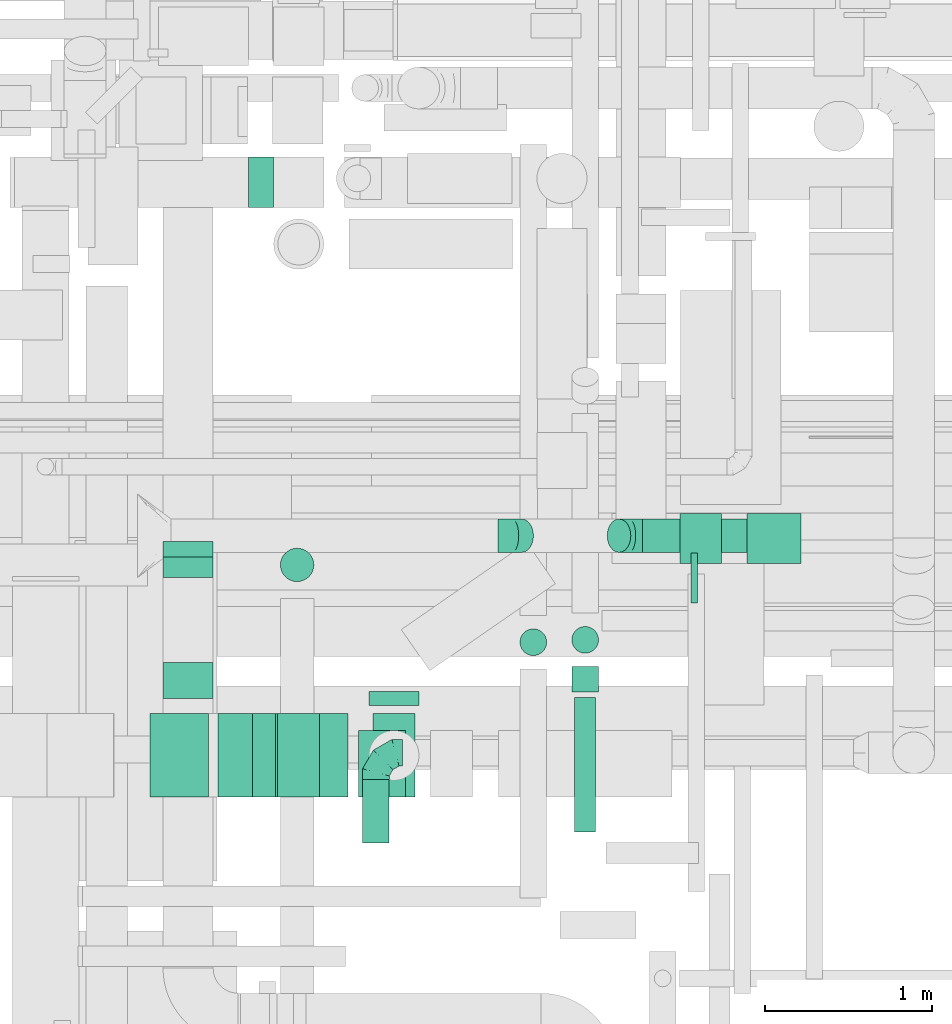
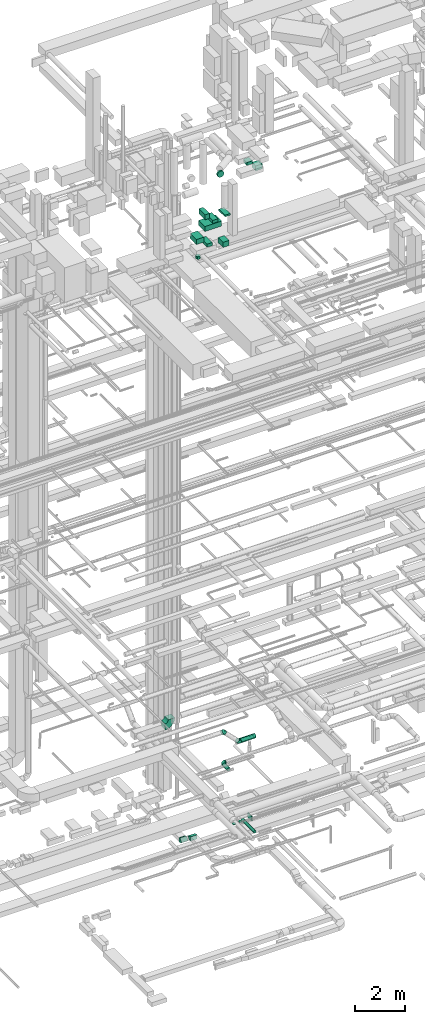
# One storey, part 140 of 337: 18 flow segments, 6 flow fittings.
"""IFC2X3 building model written with IfcOpenShell, lengths in millimetres."""

from ifc_helpers import new_model, entity, si_unit, converted_unit, derived_unit, direction, frame, frame_2d, origin, origin_2d_with_axis, place, context, subcontext, project, spatial, polyline, circle_curve, parameter, trimmed, segment, composite_curve, rectangle, circle, outline, extrude, faceted_brep, source, transform, mapped, material, type_object, type_shapes, element, save


model = new_model("IFC2X3")

# Units and contexts
model_context = context("Model", 3, precision=0.01, world=origin(), true_north=direction((6.12303176911189e-17, 1.0)))
body_context = subcontext(model_context, "Body", "Model", "MODEL_VIEW")
ifc_project = project(units=[si_unit("LENGTHUNIT", "METRE", prefix="MILLI"), si_unit("AREAUNIT", "SQUARE_METRE"), si_unit("VOLUMEUNIT", "CUBIC_METRE"), converted_unit("PLANEANGLEUNIT", "DEGREE", entity("IfcRatioMeasure", 0.0174532925199433), si_unit("PLANEANGLEUNIT", "RADIAN"), dimensions=[0, 0, 0, 0, 0, 0, 0]), si_unit("MASSUNIT", "GRAM", prefix="KILO"), derived_unit("MASSDENSITYUNIT", [(si_unit("MASSUNIT", "GRAM", prefix="KILO"), 1), (si_unit("LENGTHUNIT", "METRE"), -3)]), derived_unit("MOMENTOFINERTIAUNIT", [(si_unit("LENGTHUNIT", "METRE"), 4)]), si_unit("TIMEUNIT", "SECOND"), si_unit("FREQUENCYUNIT", "HERTZ"), si_unit("THERMODYNAMICTEMPERATUREUNIT", "DEGREE_CELSIUS"), derived_unit("THERMALTRANSMITTANCEUNIT", [(si_unit("MASSUNIT", "GRAM", prefix="KILO"), 1), (si_unit("THERMODYNAMICTEMPERATUREUNIT", "KELVIN"), -1), (si_unit("TIMEUNIT", "SECOND"), -3)]), derived_unit("VOLUMETRICFLOWRATEUNIT", [(si_unit("LENGTHUNIT", "METRE"), 3), (si_unit("TIMEUNIT", "SECOND"), -1)]), derived_unit("MASSFLOWRATEUNIT", [(si_unit("MASSUNIT", "GRAM", prefix="KILO"), 1), (si_unit("TIMEUNIT", "SECOND"), -1)]), derived_unit("ROTATIONALFREQUENCYUNIT", [(si_unit("TIMEUNIT", "SECOND"), -1)]), si_unit("ELECTRICCURRENTUNIT", "AMPERE"), si_unit("ELECTRICVOLTAGEUNIT", "VOLT"), si_unit("POWERUNIT", "WATT"), si_unit("FORCEUNIT", "NEWTON", prefix="KILO"), si_unit("ILLUMINANCEUNIT", "LUX"), si_unit("LUMINOUSFLUXUNIT", "LUMEN"), si_unit("LUMINOUSINTENSITYUNIT", "CANDELA"), derived_unit("USERDEFINED", [(si_unit("MASSUNIT", "GRAM", prefix="KILO"), -1), (si_unit("LENGTHUNIT", "METRE"), -2), (si_unit("TIMEUNIT", "SECOND"), 3), (si_unit("LUMINOUSFLUXUNIT", "LUMEN"), 1)]), derived_unit("LINEARVELOCITYUNIT", [(si_unit("LENGTHUNIT", "METRE"), 1), (si_unit("TIMEUNIT", "SECOND"), -1)]), si_unit("PRESSUREUNIT", "PASCAL"), derived_unit("USERDEFINED", [(si_unit("LENGTHUNIT", "METRE"), -2), (si_unit("MASSUNIT", "GRAM", prefix="KILO"), 1), (si_unit("TIMEUNIT", "SECOND"), -2)]), derived_unit("LINEARFORCEUNIT", [(si_unit("MASSUNIT", "GRAM", prefix="KILO"), 1), (si_unit("LENGTHUNIT", "METRE"), 1), (si_unit("TIMEUNIT", "SECOND"), -2), (si_unit("LENGTHUNIT", "METRE"), -1)]), derived_unit("PLANARFORCEUNIT", [(si_unit("MASSUNIT", "GRAM", prefix="KILO"), 1), (si_unit("LENGTHUNIT", "METRE"), 1), (si_unit("TIMEUNIT", "SECOND"), -2), (si_unit("LENGTHUNIT", "METRE"), -2)])], contexts=[model_context])

# Site, building, storey
site_placement = place(None, origin())
site = spatial("IfcSite", under=ifc_project, at=site_placement, CompositionType="ELEMENT")
building_placement = place(site_placement, origin())
building = spatial("IfcBuilding", under=site, at=building_placement, CompositionType="ELEMENT")
storey_placement = place(building_placement, origin())
storey = spatial("IfcBuildingStorey", under=building, at=storey_placement, CompositionType="ELEMENT", Elevation=0.0)

# Flow segments
duct_segment_type_1 = type_object("IfcDuctSegmentType", PredefinedType="NOTDEFINED")
flow_segment_1_placement = place(storey_placement, frame((33488.7, 9095.01, -1125.0)))
element("IfcFlowSegment", 1, at=flow_segment_1_placement, inside=storey, type_object=duct_segment_type_1, context=body_context, shape_type="SweptSolid", body=[
    extrude(rectangle(XDim=39.0201967499437, YDim=300.0, at=origin_2d_with_axis()), frame((19.51, 150.0, 0.0), z_axis=(0.0, 0.0, 1.0), x_axis=(-1.0, 0.0, 0.0)), (0.0, 0.0, 1.0), 250.0),
])
duct_segment_type_2 = type_object("IfcDuctSegmentType", PredefinedType="NOTDEFINED")
flow_segment_2_placement = place(storey_placement, frame((32462.52, 8780.33, -790.0)))
element("IfcFlowSegment", 2, at=flow_segment_2_placement, inside=storey, type_object=duct_segment_type_2, context=body_context, shape_type="SweptSolid", body=[
    extrude(circle(Radius=80.0, at=origin_2d_with_axis()), frame((81.6, 81.6, 0.0)), (0.0, 0.0, 1.0), 30.0000000000002),
])
flow_segment_3_placement = place(storey_placement, frame((33198.39, 9397.48, 2598.4)))
element("IfcFlowSegment", 3, at=flow_segment_3_placement, inside=storey, type_object=duct_segment_type_2, context=body_context, shape_type="SweptSolid", body=[
    extrude(circle(Radius=100.0, at=origin_2d_with_axis()), frame((0.0, 101.6, 101.6), z_axis=(1.0, 0.0, 0.0), x_axis=(0.0, -1.0, 0.0)), (0.0, 0.0, 1.0), 688.528137423898),
])
flow_segment_4_placement = place(storey_placement, frame((31520.43, 7660.92, 2868.4)))
element("IfcFlowSegment", 4, at=flow_segment_4_placement, inside=storey, type_object=duct_segment_type_2, context=body_context, shape_type="SweptSolid", body=[
    extrude(circle(Radius=80.0, at=origin_2d_with_axis()), frame((81.6, 0.0, 81.6), z_axis=(0.0, 1.0, 0.0), x_axis=(-1.0, 0.0, 0.0)), (0.0, 0.0, 1.0), 379.100000000156),
])
flow_segment_5_placement = place(storey_placement, frame((31558.4, 8484.5, 31548.4)))
element("IfcFlowSegment", 5, at=flow_segment_5_placement, inside=storey, type_object=duct_segment_type_2, context=body_context, shape_type="SweptSolid", body=[
    extrude(circle(Radius=150.0, at=origin_2d_with_axis()), frame((151.6, 0.0, 151.6), z_axis=(0.0, 1.0, 0.0), x_axis=(1.0, 0.0, 0.0)), (0.0, 0.0, 1.0), 82.9124965860281),
])
flow_segment_6_placement = place(storey_placement, frame((31028.91, 9222.81, 27270.0)))
element("IfcFlowSegment", 6, at=flow_segment_6_placement, inside=storey, type_object=duct_segment_type_2, context=body_context, shape_type="SweptSolid", body=[
    extrude(circle(Radius=100.0, at=origin_2d_with_axis()), frame((101.6, 101.6, 0.0), z_axis=(0.0, 0.0, 1.0), x_axis=(-1.0, 0.0, 0.0)), (0.0, 0.0, 1.0), 129.999999999992),
])
flow_segment_7_placement = place(storey_placement, frame((32790.38, 7724.77, -664.1)))
element("IfcFlowSegment", 7, at=flow_segment_7_placement, inside=storey, type_object=duct_segment_type_2, context=body_context, shape_type="SweptSolid", body=[
    extrude(circle(Radius=62.5, at=origin_2d_with_axis()), frame((64.1, 0.0, 64.1), z_axis=(0.0, 1.0, 0.0), x_axis=(1.0, 0.0, 0.0)), (0.0, 0.0, 1.0), 805.000000000003),
])
flow_segment_8_placement = place(storey_placement, frame((32772.88, 8564.77, -681.6)))
element("IfcFlowSegment", 8, at=flow_segment_8_placement, inside=storey, type_object=duct_segment_type_2, context=body_context, shape_type="SweptSolid", body=[
    extrude(circle(Radius=80.0, at=origin_2d_with_axis()), frame((81.6, 0.0, 81.6), z_axis=(0.0, 1.0, 0.0), x_axis=(-1.0, 0.0, 0.0)), (0.0, 0.0, 1.0), 151.070569999958),
])
flow_segment_9_placement = place(storey_placement, frame((32772.88, 8794.25, -790.0)))
element("IfcFlowSegment", 9, at=flow_segment_9_placement, inside=storey, type_object=duct_segment_type_2, context=body_context, shape_type="SweptSolid", body=[
    extrude(circle(Radius=80.0, at=origin_2d_with_axis()), frame((81.6, 81.6, 0.0), z_axis=(0.0, 0.0, 1.0), x_axis=(-1.0, 0.0, 0.0)), (0.0, 0.0, 1.0), 30.0000000000277),
])
duct_segment_type_3 = type_object("IfcDuctSegmentType", PredefinedType="NOTDEFINED")
flow_segment_10_placement = place(storey_placement, frame((30655.36, 7934.5, 29575.0)))
element("IfcFlowSegment", 10, at=flow_segment_10_placement, inside=storey, type_object=duct_segment_type_3, context=body_context, shape_type="SweptSolid", body=[
    extrude(rectangle(XDim=779.641735586025, YDim=500.0, at=origin_2d_with_axis()), frame((389.82, 250.0, 0.0)), (0.0, 0.0, 1.0), 250.000000000004),
])
flow_segment_11_placement = place(storey_placement, frame((30658.06, 7934.5, 30150.0)))
element("IfcFlowSegment", 11, at=flow_segment_11_placement, inside=storey, type_object=duct_segment_type_3, context=body_context, shape_type="SweptSolid", body=[
    extrude(rectangle(XDim=205.855431162575, YDim=500.0, at=origin_2d_with_axis()), frame((102.93, 250.0, 0.0)), (0.0, 0.0, 1.0), 250.000000000004),
])
flow_segment_12_placement = place(storey_placement, frame((31013.92, 7934.5, 29845.0)))
element("IfcFlowSegment", 12, at=flow_segment_12_placement, inside=storey, type_object=duct_segment_type_3, context=body_context, shape_type="SweptSolid", body=[
    extrude(rectangle(XDim=250.000000000004, YDim=500.0, at=origin_2d_with_axis()), frame((125.0, 250.0, 0.0), z_axis=(0.0, 0.0, 1.0), x_axis=(-1.0, 0.0, 0.0)), (0.0, 0.0, 1.0), 154.999999999978),
])
flow_segment_13_placement = place(storey_placement, frame((31585.0, 7934.5, 29975.0)))
element("IfcFlowSegment", 13, at=flow_segment_13_placement, inside=storey, type_object=duct_segment_type_3, context=body_context, shape_type="SweptSolid", body=[
    extrude(rectangle(XDim=250.000000000004, YDim=500.0, at=origin_2d_with_axis()), frame((125.0, 250.0, 0.0)), (0.0, 0.0, 1.0), 76.9999999999868),
])
flow_segment_14_placement = place(storey_placement, frame((31497.03, 7934.51, 28500.0)))
element("IfcFlowSegment", 14, at=flow_segment_14_placement, inside=storey, type_object=duct_segment_type_3, context=body_context, shape_type="SweptSolid", body=[
    extrude(rectangle(XDim=282.46671500016, YDim=400.0, at=origin_2d_with_axis()), frame((141.23, 200.0, 0.0), z_axis=(0.0, 0.0, 1.0), x_axis=(-1.0, 0.0, 0.0)), (0.0, 0.0, 1.0), 250.000000000004),
])
flow_segment_15_placement = place(storey_placement, frame((30250.84, 7934.5, 29075.0)))
element("IfcFlowSegment", 15, at=flow_segment_15_placement, inside=storey, type_object=duct_segment_type_3, context=body_context, shape_type="SweptSolid", body=[
    extrude(rectangle(XDim=350.488799910469, YDim=500.0, at=origin_2d_with_axis()), frame((175.24, 250.0, 0.0), z_axis=(0.0, 0.0, 1.0), x_axis=(-1.0, 0.0, 0.0)), (0.0, 0.0, 1.0), 250.000000000004),
])
flow_segment_16_placement = place(storey_placement, frame((30751.33, 7934.5, 28770.0)))
element("IfcFlowSegment", 16, at=flow_segment_16_placement, inside=storey, type_object=duct_segment_type_3, context=body_context, shape_type="SweptSolid", body=[
    extrude(rectangle(XDim=250.000000000004, YDim=500.0, at=origin_2d_with_axis()), frame((125.0, 250.0, 0.0), z_axis=(0.0, 0.0, 1.0), x_axis=(-1.0, 0.0, 0.0)), (0.0, 0.0, 1.0), 154.999999999956),
])
flow_segment_17_placement = place(storey_placement, frame((33821.59, 9332.41, 30600.0)))
element("IfcFlowSegment", 17, at=flow_segment_17_placement, inside=storey, type_object=duct_segment_type_3, context=body_context, shape_type="SweptSolid", body=[
    extrude(rectangle(XDim=324.394797118785, YDim=300.0, at=origin_2d_with_axis()), frame((162.2, 150.0, 0.0), z_axis=(0.0, 0.0, 1.0), x_axis=(-1.0, 0.0, 0.0)), (0.0, 0.0, 1.0), 250.000000000004),
])
flow_segment_18_placement = place(storey_placement, frame((33421.59, 9332.41, 31000.0)))
element("IfcFlowSegment", 18, at=flow_segment_18_placement, inside=storey, type_object=duct_segment_type_3, context=body_context, shape_type="SweptSolid", body=[
    extrude(rectangle(XDim=300.000000000001, YDim=249.999999999999, at=origin_2d_with_axis()), frame((125.0, 150.0, 0.0), z_axis=(0.0, 0.0, 1.0), x_axis=(0.0, -1.0, 0.0)), (0.0, 0.0, 1.0), 154.999999999999),
])

# Flow fittings
ifc_material = material()
duct_fitting_type_1 = type_object("IfcDuctFittingType", PredefinedType="NOTDEFINED", material=ifc_material)
shared_shape_1 = source(origin(), body_context, "Body", "Brep", [
    faceted_brep([(-160.0, 0.0, -80.0), (-160.0, -20.71, -77.27), (-160.0, -40.0, -69.28), (-160.0, -56.57, -56.57), (-160.0, -69.28, -40.0), (-160.0, -77.27, -20.71), (-160.0, -80.0, 0.0), (-160.0, -77.27, 20.71), (-160.0, -69.28, 40.0), (-160.0, -56.57, 56.57), (-160.0, -40.0, 69.28), (-160.0, -20.71, 77.27), (-160.0, 0.0, 80.0), (-160.0, 20.71, 77.27), (-160.0, 40.0, 69.28), (-160.0, 56.57, 56.57), (-160.0, 69.28, 40.0), (-160.0, 77.27, 20.71), (-160.0, 80.0, 0.0), (-160.0, 77.27, -20.71), (-160.0, 69.28, -40.0), (-160.0, 56.57, -56.57), (-160.0, 40.0, -69.28), (-160.0, 20.71, -77.27), (-122.68, 20.71, 77.27), (-127.85, 40.0, 69.28), (-117.13, 0.0, 80.0), (-132.29, 56.57, 56.57), (-137.83, 77.27, 20.71), (-138.56, 80.0, 0.0), (-135.69, 69.28, 40.0), (-135.69, 69.28, -40.0), (-132.29, 56.57, -56.57), (-137.83, 77.27, -20.71), (-122.68, 20.71, -77.27), (-117.13, 0.0, -80.0), (-127.85, 40.0, -69.28), (-111.58, -20.71, -77.27), (-106.41, -40.0, -69.28), (-101.97, -56.57, -56.57), (-98.56, -69.28, -40.0), (-96.42, -77.27, -20.71), (-95.69, -80.0, 0.0), (-96.42, -77.27, 20.71), (-98.56, -69.28, 40.0), (-101.97, -56.57, 56.57), (-106.41, -40.0, 69.28), (-111.58, -20.71, 77.27), (-58.03, 58.03, 77.27), (-72.15, 72.15, 69.28), (-42.87, 42.87, 80.0), (-84.28, 84.28, 56.57), (-93.59, 93.59, 40.0), (-99.44, 99.44, 20.71), (-101.44, 101.44, 0.0), (-99.44, 99.44, -20.71), (-93.59, 93.59, -40.0), (-84.28, 84.28, -56.57), (-58.03, 58.03, -77.27), (-42.87, 42.87, -80.0), (-72.15, 72.15, -69.28), (-27.71, 27.71, -77.27), (-13.59, 13.59, -69.28), (-1.46, 1.46, -56.57), (7.85, -7.85, -40.0), (13.7, -13.7, -20.71), (15.69, -15.69, 0.0), (13.7, -13.7, 20.71), (7.85, -7.85, 40.0), (-1.46, 1.46, 56.57), (-13.59, 13.59, 69.28), (-27.71, 27.71, 77.27), (-20.71, 122.68, 77.27), (-40.0, 127.85, 69.28), (0.0, 117.13, 80.0), (-56.57, 132.29, 56.57), (-69.28, 135.69, 40.0), (-77.27, 137.83, 20.71), (-80.0, 138.56, 0.0), (-77.27, 137.83, -20.71), (-69.28, 135.69, -40.0), (-56.57, 132.29, -56.57), (-20.71, 122.68, -77.27), (0.0, 117.13, -80.0), (-40.0, 127.85, -69.28), (20.71, 111.58, -77.27), (40.0, 106.41, -69.28), (56.57, 101.97, -56.57), (69.28, 98.56, -40.0), (77.27, 96.42, -20.71), (80.0, 95.69, 0.0), (77.27, 96.42, 20.71), (69.28, 98.56, 40.0), (56.57, 101.97, 56.57), (40.0, 106.41, 69.28), (20.71, 111.58, 77.27), (-20.71, 160.0, -77.27), (-40.0, 160.0, -69.28), (-56.57, 160.0, -56.57), (-69.28, 160.0, -40.0), (-77.27, 160.0, -20.71), (-80.0, 160.0, 0.0), (-77.27, 160.0, 20.71), (-69.28, 160.0, 40.0), (-56.57, 160.0, 56.57), (-40.0, 160.0, 69.28), (-20.71, 160.0, 77.27), (0.0, 160.0, 80.0), (20.71, 160.0, 77.27), (40.0, 160.0, 69.28), (56.57, 160.0, 56.57), (69.28, 160.0, 40.0), (77.27, 160.0, 20.71), (80.0, 160.0, 0.0), (77.27, 160.0, -20.71), (69.28, 160.0, -40.0), (56.57, 160.0, -56.57), (40.0, 160.0, -69.28), (20.71, 160.0, -77.27), (0.0, 160.0, -80.0)], [[[0, 1, 2, 3, 4, 5, 6, 7, 8, 9, 10, 11, 12, 13, 14, 15, 16, 17, 18, 19, 20, 21, 22, 23]], [[24, 25, 14, 13]], [[26, 24, 13, 12]], [[14, 25, 27, 15]], [[28, 29, 18, 17]], [[30, 28, 17, 16]], [[15, 27, 30, 16]], [[20, 31, 32, 21]], [[33, 31, 20, 19]], [[18, 29, 33, 19]], [[34, 35, 0, 23]], [[36, 34, 23, 22]], [[32, 36, 22, 21]], [[1, 0, 35, 37]], [[2, 1, 37, 38]], [[3, 2, 38, 39]], [[5, 4, 40, 41]], [[6, 5, 41, 42]], [[39, 40, 4, 3]], [[6, 42, 43, 7]], [[7, 43, 44, 8]], [[8, 44, 45, 9]], [[9, 45, 46, 10]], [[10, 46, 47, 11]], [[26, 12, 11, 47]], [[48, 49, 25, 24]], [[50, 48, 24, 26]], [[27, 25, 49, 51]], [[52, 53, 28, 30]], [[51, 52, 30, 27]], [[29, 28, 53, 54]], [[55, 56, 31, 33]], [[54, 55, 33, 29]], [[32, 31, 56, 57]], [[58, 59, 35, 34]], [[60, 58, 34, 36]], [[57, 60, 36, 32]], [[37, 35, 59, 61]], [[38, 37, 61, 62]], [[39, 38, 62, 63]], [[41, 40, 64, 65]], [[42, 41, 65, 66]], [[63, 64, 40, 39]], [[43, 42, 66, 67]], [[44, 43, 67, 68]], [[68, 69, 45, 44]], [[46, 45, 69, 70]], [[47, 46, 70, 71]], [[26, 47, 71, 50]], [[72, 73, 49, 48]], [[74, 72, 48, 50]], [[51, 49, 73, 75]], [[76, 77, 53, 52]], [[75, 76, 52, 51]], [[54, 53, 77, 78]], [[79, 80, 56, 55]], [[78, 79, 55, 54]], [[57, 56, 80, 81]], [[82, 83, 59, 58]], [[84, 82, 58, 60]], [[81, 84, 60, 57]], [[61, 59, 83, 85]], [[62, 61, 85, 86]], [[63, 62, 86, 87]], [[65, 64, 88, 89]], [[66, 65, 89, 90]], [[87, 88, 64, 63]], [[67, 66, 90, 91]], [[68, 67, 91, 92]], [[92, 93, 69, 68]], [[70, 69, 93, 94]], [[71, 70, 94, 95]], [[50, 71, 95, 74]], [[96, 97, 98, 99, 100, 101, 102, 103, 104, 105, 106, 107, 108, 109, 110, 111, 112, 113, 114, 115, 116, 117, 118, 119]], [[72, 74, 107, 106]], [[73, 72, 106, 105]], [[75, 73, 105, 104]], [[77, 76, 103, 102]], [[78, 77, 102, 101]], [[75, 104, 103, 76]], [[78, 101, 100, 79]], [[79, 100, 99, 80]], [[80, 99, 98, 81]], [[84, 97, 96, 82]], [[82, 96, 119, 83]], [[84, 81, 98, 97]], [[118, 117, 86, 85]], [[119, 118, 85, 83]], [[116, 87, 86, 117]], [[88, 115, 114, 89]], [[89, 114, 113, 90]], [[115, 88, 87, 116]], [[112, 111, 92, 91]], [[113, 112, 91, 90]], [[111, 110, 93, 92]], [[95, 94, 109, 108]], [[74, 95, 108, 107]], [[110, 109, 94, 93]]]),
])
type_shapes(duct_fitting_type_1, [shared_shape_1])
flow_fitting_1_placement = place(storey_placement, frame((31602.03, 8200.02, 2950.0), z_axis=(0.0, 0.0, 1.0), x_axis=(-1.0, 0.0, 0.0)))
element("IfcFlowFitting", 19, at=flow_fitting_1_placement, inside=storey, type_object=duct_fitting_type_1, material=ifc_material, context=body_context, shape_type="MappedRepresentation", body=[
    mapped(shared_shape_1, transform((0.0, 0.0, 0.0), scale=1.0)),
])
duct_fitting_type_2 = type_object("IfcDuctFittingType", PredefinedType="NOTDEFINED", material=ifc_material)
shared_shape_2 = source(origin(), body_context, "Body", "Brep", [
    faceted_brep([(-82.84, 0.0, -100.0), (-82.84, -25.88, -96.59), (-82.84, -50.0, -86.6), (-82.84, -70.71, -70.71), (-82.84, -86.6, -50.0), (-82.84, -96.59, -25.88), (-82.84, -100.0, 0.0), (-82.84, -96.59, 25.88), (-82.84, -86.6, 50.0), (-82.84, -70.71, 70.71), (-82.84, -50.0, 86.6), (-82.84, -25.88, 96.59), (-82.84, 0.0, 100.0), (-82.84, 25.88, 96.59), (-82.84, 50.0, 86.6), (-82.84, 70.71, 70.71), (-82.84, 86.6, 50.0), (-82.84, 96.59, 25.88), (-82.84, 100.0, 0.0), (-82.84, 96.59, -25.88), (-82.84, 86.6, -50.0), (-82.84, 70.71, -70.71), (-82.84, 50.0, -86.6), (-82.84, 25.88, -96.59), (-10.72, 25.88, 96.59), (-20.71, 50.0, 86.6), (0.0, 0.0, 100.0), (-29.29, 70.71, 70.71), (-35.87, 86.6, 50.0), (-40.01, 96.59, 25.88), (-41.42, 100.0, 0.0), (-40.01, 96.59, -25.88), (-35.87, 86.6, -50.0), (-29.29, 70.71, -70.71), (-10.72, 25.88, -96.59), (0.0, 0.0, -100.0), (-20.71, 50.0, -86.6), (10.72, -25.88, -96.59), (20.71, -50.0, -86.6), (29.29, -70.71, -70.71), (35.87, -86.6, -50.0), (40.01, -96.59, -25.88), (41.42, -100.0, 0.0), (40.01, -96.59, 25.88), (35.87, -86.6, 50.0), (29.29, -70.71, 70.71), (20.71, -50.0, 86.6), (10.72, -25.88, 96.59), (58.58, 58.58, 100.0), (40.28, 76.88, 96.59), (23.22, 93.93, 86.6), (8.58, 108.58, 70.71), (-2.66, 119.82, 50.0), (-9.72, 126.88, 25.88), (-12.13, 129.29, 0.0), (-9.72, 126.88, -25.88), (-2.66, 119.82, -50.0), (8.58, 108.58, -70.71), (23.22, 93.93, -86.6), (40.28, 76.88, -96.59), (58.58, 58.58, -100.0), (76.88, 40.28, -96.59), (93.93, 23.22, -86.6), (108.58, 8.58, -70.71), (119.82, -2.66, -50.0), (126.88, -9.72, -25.88), (129.29, -12.13, 0.0), (126.88, -9.72, 25.88), (119.82, -2.66, 50.0), (108.58, 8.58, 70.71), (93.93, 23.22, 86.6), (76.88, 40.28, 96.59)], [[[0, 1, 2, 3, 4, 5, 6, 7, 8, 9, 10, 11, 12, 13, 14, 15, 16, 17, 18, 19, 20, 21, 22, 23]], [[24, 25, 14, 13]], [[26, 24, 13, 12]], [[14, 25, 27, 15]], [[28, 29, 17, 16]], [[28, 16, 15, 27]], [[30, 18, 17, 29]], [[31, 32, 20, 19]], [[30, 31, 19, 18]], [[32, 33, 21, 20]], [[34, 35, 0, 23]], [[36, 34, 23, 22]], [[33, 36, 22, 21]], [[1, 0, 35, 37]], [[2, 1, 37, 38]], [[38, 39, 3, 2]], [[5, 4, 40, 41]], [[6, 5, 41, 42]], [[39, 40, 4, 3]], [[6, 42, 43, 7]], [[7, 43, 44, 8]], [[8, 44, 45, 9]], [[9, 45, 46, 10]], [[10, 46, 47, 11]], [[26, 12, 11, 47]], [[24, 26, 48, 49]], [[25, 24, 49, 50]], [[27, 25, 50, 51]], [[29, 28, 52, 53]], [[30, 29, 53, 54]], [[51, 52, 28, 27]], [[30, 54, 55, 31]], [[31, 55, 56, 32]], [[57, 33, 32, 56]], [[36, 58, 59, 34]], [[34, 59, 60, 35]], [[58, 36, 33, 57]], [[35, 60, 61, 37]], [[37, 61, 62, 38]], [[63, 39, 38, 62]], [[40, 64, 65, 41]], [[41, 65, 66, 42]], [[64, 40, 39, 63]], [[43, 42, 66, 67]], [[44, 43, 67, 68]], [[68, 69, 45, 44]], [[47, 46, 70, 71]], [[26, 47, 71, 48]], [[69, 70, 46, 45]], [[59, 58, 57, 56, 55, 54, 53, 52, 51, 50, 49, 48, 71, 70, 69, 68, 67, 66, 65, 64, 63, 62, 61, 60]]]),
])
type_shapes(duct_fitting_type_2, [shared_shape_2])
for number, where, z_axis, x_axis in (
    (20, (32415.55, 9499.08, 3400.0), (0.0, 1.0, 0.0), (1.0, 0.0, 0.0)),
    (21, (33115.55, 9499.08, 2700.0), (0.0, -1.0, 0.0), (0.707106781186541, 0.0, -0.707106781186554)),
):
    element("IfcFlowFitting", number, at=place(storey_placement, frame(where, z_axis=z_axis, x_axis=x_axis)), inside=storey, type_object=duct_fitting_type_2, material=ifc_material, context=body_context, shape_type="MappedRepresentation", body=[
        mapped(shared_shape_2, transform((0.0, 0.0, 0.0), scale=1.0)),
    ])
duct_fitting_type_3 = type_object("IfcDuctFittingType", PredefinedType="NOTDEFINED", material=ifc_material)
shared_shape_3 = source(origin(), body_context, "Body", "SweptSolid", [
    extrude(outline(composite_curve([segment(polyline([(-300.0, -150.0), (0.0, -150.0)]), True, "CONTINUOUS"), segment(trimmed(circle_curve(frame_2d((150.0, -150.0), x_axis=(0.0, 1.0)), 150.0), [parameter(0.0)], [parameter(90.0)], True, "PARAMETER"), False, "CONTINUOUS"), segment(polyline([(150.0, 0.0), (150.0, 300.0)]), True, "CONTINUOUS"), segment(trimmed(circle_curve(frame_2d((150.0, -150.0), x_axis=(0.0, 1.0)), 450.0), [parameter(0.0)], [parameter(90.0000000000001)], True, "PARAMETER"), True, "CONTINUOUS")], self_intersect=False)), frame((-150.0, 150.0, -150.0), z_axis=(0.0, 0.0, 1.0), x_axis=(-1.0, 0.0, 0.0)), (0.0, 0.0, 1.0), 300.0),
])
type_shapes(duct_fitting_type_3, [shared_shape_3])
flow_fitting_2_placement = place(storey_placement, frame((31140.08, 11614.96, 3000.0), z_axis=(0.0, -1.0, 0.0), x_axis=(1.0, 0.0, 0.0)))
element("IfcFlowFitting", 22, at=flow_fitting_2_placement, inside=storey, type_object=duct_fitting_type_3, material=ifc_material, context=body_context, shape_type="MappedRepresentation", body=[
    mapped(shared_shape_3, transform((0.0, 0.0, 0.0), scale=1.0)),
])
duct_fitting_type_4 = type_object("IfcDuctFittingType", PredefinedType="NOTDEFINED", material=ifc_material)
shared_shape_4 = source(origin(), body_context, "Body", "SweptSolid", [
    extrude(outline(composite_curve([segment(polyline([(-126.56, -77.03), (73.44, -77.03)]), True, "CONTINUOUS"), segment(trimmed(circle_curve(frame_2d((223.44, -77.03), x_axis=(-0.78755656558419, 0.616242367908306)), 150.0), [parameter(0.0)], [parameter(38.0422485176263)], True, "PARAMETER"), False, "CONTINUOUS"), segment(polyline([(105.31, 15.41), (-52.2, 138.65)]), True, "CONTINUOUS"), segment(trimmed(circle_curve(frame_2d((223.44, -77.03), x_axis=(-0.78755656558419, 0.616242367908306)), 350.0), [parameter(0.0)], [parameter(38.0422485176263)], True, "PARAMETER"), True, "CONTINUOUS")], self_intersect=False)), frame((-9.15, 26.56, -150.0), z_axis=(0.0, 0.0, 1.0), x_axis=(-0.616242367908305, 0.78755656558419, 0.0)), (0.0, 0.0, 1.0), 300.0),
])
type_shapes(duct_fitting_type_4, [shared_shape_4])
for number, where, z_axis, x_axis in (
    (23, (30477.78, 8610.62, -550.0), (-1.0, 0.0, 0.0), (0.0, 1.0, 0.0)),
    (24, (30477.78, 9377.42, -1150.0), (1.0, 0.0, 0.0), (0.0, 0.78755656558419, -0.616242367908306)),
):
    element("IfcFlowFitting", number, at=place(storey_placement, frame(where, z_axis=z_axis, x_axis=x_axis)), inside=storey, type_object=duct_fitting_type_4, material=ifc_material, context=body_context, shape_type="MappedRepresentation", body=[
        mapped(shared_shape_4, transform((0.0, 0.0, 0.0), scale=1.0)),
    ])

save(model, "model.ifc")
